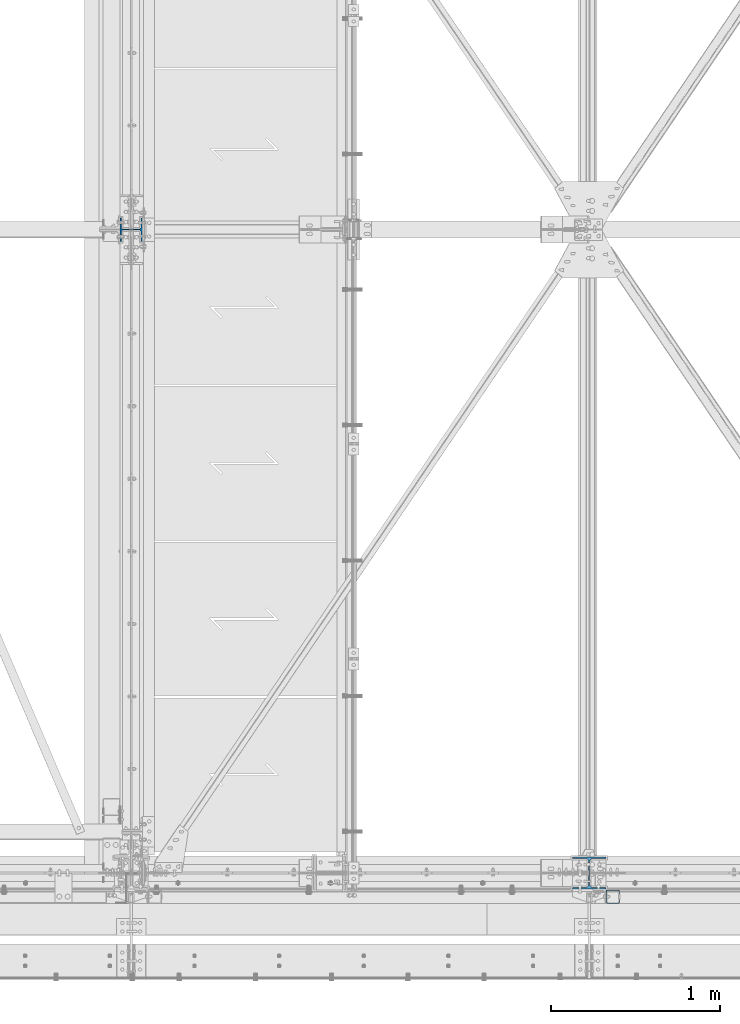
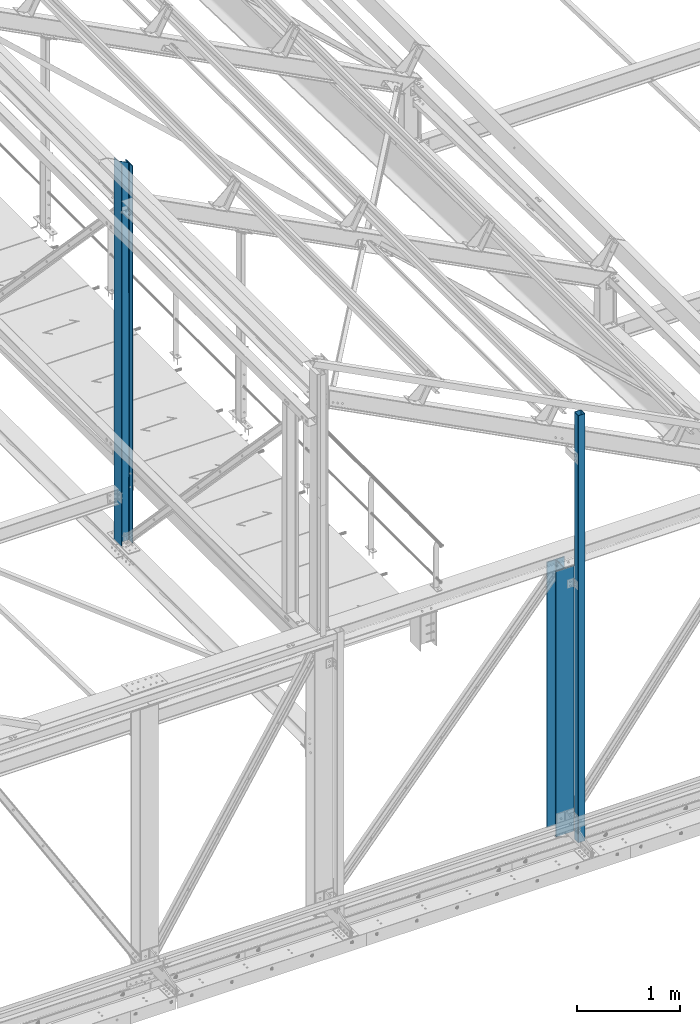
# One storey, part 9 of 496: 3 columns, 3 elements without a shape of their own.
"""IFC2X3 building model written with IfcOpenShell, lengths in millimetres."""

from ifc_helpers import new_model, si_unit, frame, origin_with_axes, origin_2d_with_axis, place, context, subcontext, project, spatial, hollow_rectangle, i_section, extrude, clip, halfspace, material, type_object, element, aggregate, save


model = new_model("IFC2X3")

# Units and contexts
model_context = context("Model", 3, precision=1e-05, world=origin_with_axes())
body_context = subcontext(model_context, "Body", "Model", "MODEL_VIEW")
ifc_project = project(units=[si_unit("LENGTHUNIT", "METRE", prefix="MILLI"), si_unit("AREAUNIT", "SQUARE_METRE"), si_unit("VOLUMEUNIT", "CUBIC_METRE"), si_unit("MASSUNIT", "GRAM", prefix="KILO"), si_unit("TIMEUNIT", "SECOND"), si_unit("PLANEANGLEUNIT", "RADIAN"), si_unit("SOLIDANGLEUNIT", "STERADIAN"), si_unit("THERMODYNAMICTEMPERATUREUNIT", "DEGREE_CELSIUS"), si_unit("LUMINOUSINTENSITYUNIT", "LUMEN")], contexts=[model_context])

# Site, building, storey
site_placement = place(None, origin_with_axes())
site = spatial("IfcSite", under=ifc_project, at=site_placement, CompositionType="ELEMENT")
building_placement = place(site_placement, origin_with_axes())
building = spatial("IfcBuilding", under=site, at=building_placement, Name="Undefined", CompositionType="ELEMENT")
storey_placement = place(building_placement, origin_with_axes())
storey = spatial("IfcBuildingStorey", under=building, at=storey_placement, Name="Undefined", CompositionType="ELEMENT", Elevation=0.0)

# Assembly, column
assembly_1_placement = place(storey_placement, origin_with_axes())
assembly_1 = element("IfcElementAssembly", 1, at=assembly_1_placement, inside=storey, Name="MONTANT", AssemblyPlace="NOTDEFINED", PredefinedType="NOTDEFINED")
ifc_material_1 = material(Name="Undefined/S235-E24")
column_type_1 = type_object("IfcColumnType", PredefinedType="NOTDEFINED")
column_1_placement = place(assembly_1_placement, frame((26314.9999999968, -139.999999995448, 5109.99999997825), z_axis=(0.0, 0.0, 1.0), x_axis=(0.0, 1.0, 0.0)))
column_1 = element("IfcColumn", 2, at=column_1_placement, type_object=column_type_1, material=ifc_material_1, Name="MONTANT", context=body_context, shape_type="SweptSolid", body=[
    extrude(hollow_rectangle(XDim=80.0, YDim=80.0, WallThickness=4.0, InnerFilletRadius=4.0, OuterFilletRadius=8.0, at=origin_2d_with_axis()), frame((0.0, 0.0, 5070.00143645498), z_axis=(0.0, 0.0, -1.0), x_axis=(0.0, 1.0, 0.0)), (0.0, 0.0, 1.0), 5070.0),
])
aggregate(assembly_1, [column_1])

assembly_2_placement = place(storey_placement, origin_with_axes())
assembly_2 = element("IfcElementAssembly", 3, at=assembly_2_placement, inside=storey, Name="MONTANT", AssemblyPlace="NOTDEFINED", PredefinedType="NOTDEFINED")
ifc_material_2 = material(Name="Undefined/S275-E28")
column_type_2 = type_object("IfcColumnType", Name="HEA140", PredefinedType="NOTDEFINED")
column_2_placement = place(assembly_2_placement, frame((23470.0, 3800.0, 7260.0), z_axis=(0.0, 0.0, 1.0), x_axis=(-1.0, 0.0, 0.0)))
column_2 = element("IfcColumn", 4, at=column_2_placement, type_object=column_type_2, material=ifc_material_2, Name="MONTANT", ObjectType="HEA140", context=body_context, shape_type="Clipping", body=[
    clip(extrude(i_section(OverallWidth=140.0, OverallDepth=133.0, WebThickness=5.5, FlangeThickness=8.5, FilletRadius=12.0, at=origin_2d_with_axis()), frame((0.0, 0.0, 4551.40988027575), z_axis=(0.0, 0.0, -1.0), x_axis=(0.0, 1.0, 0.0)), (0.0, 0.0, 1.0), 4551.41), halfspace(frame((-66.5, 70.0, 4471.22657322575), z_axis=(-0.460093242228747, -7.1029704621934e-09, 0.887870603441425), x_axis=(0.887870603441425, 0.0, 0.460093242228747)), False)),
])
aggregate(assembly_2, [column_2])

assembly_3_placement = place(storey_placement, origin_with_axes())
assembly_3 = element("IfcElementAssembly", 5, at=assembly_3_placement, inside=storey, Name="MONTANT", AssemblyPlace="NOTDEFINED", PredefinedType="NOTDEFINED")
column_type_3 = type_object("IfcColumnType", Name="HEA200", PredefinedType="NOTDEFINED")
column_3_placement = place(assembly_3_placement, frame((26175.0, 0.0, 5200.0), z_axis=(0.0, 0.0, 1.0), x_axis=(0.0, 1.0, 0.0)))
column_3 = element("IfcColumn", 6, at=column_3_placement, type_object=column_type_3, material=ifc_material_2, Name="MONTANT", ObjectType="HEA200", context=body_context, shape_type="SweptSolid", body=[
    extrude(i_section(OverallWidth=200.0, OverallDepth=190.0, WebThickness=6.5, FlangeThickness=10.0, FilletRadius=18.0, at=origin_2d_with_axis()), frame((0.0, 0.0, 3149.99444626714), z_axis=(0.0, 0.0, -1.0), x_axis=(0.0, 1.0, 0.0)), (0.0, 0.0, 1.0), 3149.99),
])
aggregate(assembly_3, [column_3])

save(model, "model.ifc")
